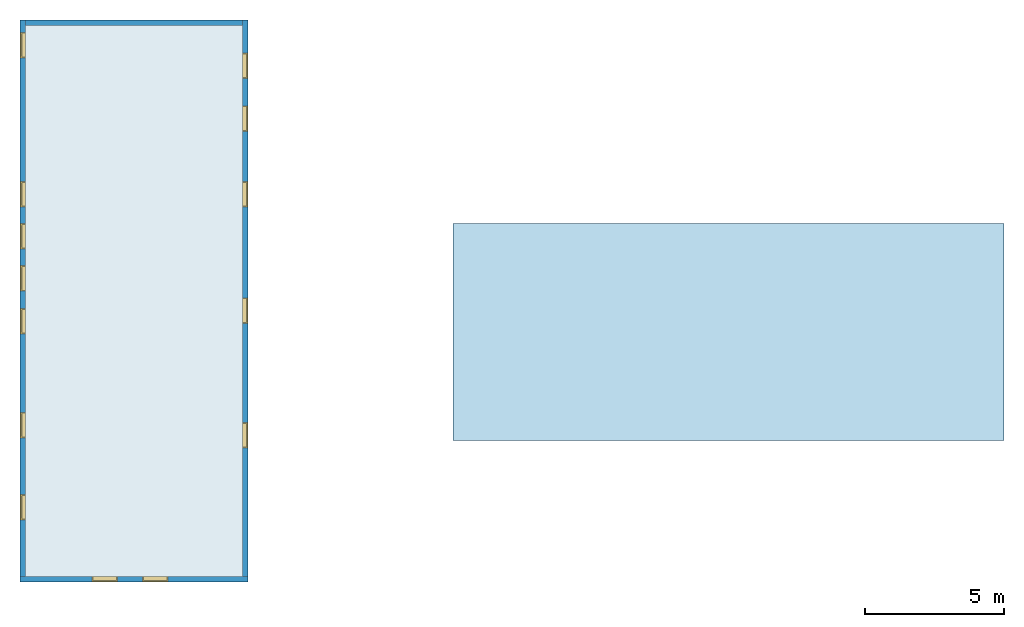
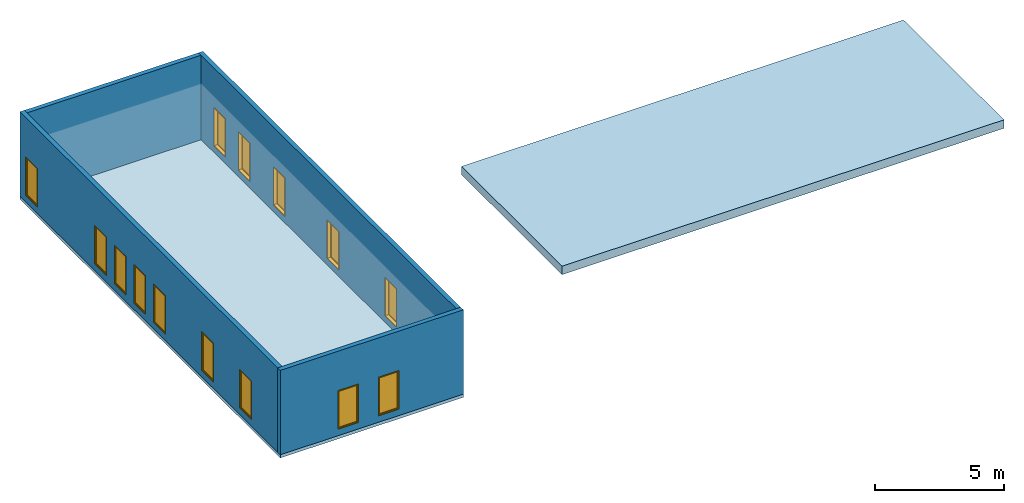
# One storey, part 1 of 2: 14 windows, 4 walls, 2 slabs, 14 openings, 1 element without a shape of its own.
"""IFC2X3 building model written with IfcOpenShell, lengths in millimetres."""

from ifc_helpers import new_model, entity, si_unit, converted_unit, derived_unit, direction, frame, frame_2d, origin, place, context, subcontext, project, spatial, polyline, rectangle, outline, extrude, source, transform, mapped, material, material_list, layer, layer_set, layer_usage, type_object, type_shapes, element, fill, aggregate, save


model = new_model("IFC2X3")

# Units and contexts
model_context = context("Model", 3, precision=0.01, world=origin(), true_north=direction((6.12303176911189e-17, 1.0)))
body_context = subcontext(model_context, "Body", "Model", "MODEL_VIEW")
ifc_project = project(units=[si_unit("LENGTHUNIT", "METRE", prefix="MILLI"), si_unit("AREAUNIT", "SQUARE_METRE"), si_unit("VOLUMEUNIT", "CUBIC_METRE"), converted_unit("PLANEANGLEUNIT", "DEGREE", entity("IfcRatioMeasure", 0.0174532925199433), si_unit("PLANEANGLEUNIT", "RADIAN"), dimensions=[0, 0, 0, 0, 0, 0, 0]), si_unit("MASSUNIT", "GRAM", prefix="KILO"), derived_unit("MASSDENSITYUNIT", [(si_unit("MASSUNIT", "GRAM", prefix="KILO"), 1), (si_unit("LENGTHUNIT", "METRE"), -3)]), derived_unit("MOMENTOFINERTIAUNIT", [(si_unit("LENGTHUNIT", "METRE"), 4)]), si_unit("TIMEUNIT", "SECOND"), si_unit("FREQUENCYUNIT", "HERTZ"), si_unit("THERMODYNAMICTEMPERATUREUNIT", "DEGREE_CELSIUS"), derived_unit("THERMALTRANSMITTANCEUNIT", [(si_unit("MASSUNIT", "GRAM", prefix="KILO"), 1), (si_unit("THERMODYNAMICTEMPERATUREUNIT", "KELVIN"), -1), (si_unit("TIMEUNIT", "SECOND"), -3)]), derived_unit("VOLUMETRICFLOWRATEUNIT", [(si_unit("LENGTHUNIT", "METRE"), 3), (si_unit("TIMEUNIT", "SECOND"), -1)]), si_unit("ELECTRICCURRENTUNIT", "AMPERE"), si_unit("ELECTRICVOLTAGEUNIT", "VOLT"), si_unit("POWERUNIT", "WATT"), si_unit("FORCEUNIT", "NEWTON", prefix="KILO"), si_unit("ILLUMINANCEUNIT", "LUX"), si_unit("LUMINOUSFLUXUNIT", "LUMEN"), si_unit("LUMINOUSINTENSITYUNIT", "CANDELA"), derived_unit("USERDEFINED", [(si_unit("MASSUNIT", "GRAM", prefix="KILO"), -1), (si_unit("LENGTHUNIT", "METRE"), -2), (si_unit("TIMEUNIT", "SECOND"), 3), (si_unit("LUMINOUSFLUXUNIT", "LUMEN"), 1)]), derived_unit("LINEARVELOCITYUNIT", [(si_unit("LENGTHUNIT", "METRE"), 1), (si_unit("TIMEUNIT", "SECOND"), -1)]), si_unit("PRESSUREUNIT", "PASCAL"), derived_unit("USERDEFINED", [(si_unit("LENGTHUNIT", "METRE"), -2), (si_unit("MASSUNIT", "GRAM", prefix="KILO"), 1), (si_unit("TIMEUNIT", "SECOND"), -2)]), derived_unit("LINEARFORCEUNIT", [(si_unit("MASSUNIT", "GRAM", prefix="KILO"), 1), (si_unit("LENGTHUNIT", "METRE"), 1), (si_unit("TIMEUNIT", "SECOND"), -2), (si_unit("LENGTHUNIT", "METRE"), -1)]), derived_unit("PLANARFORCEUNIT", [(si_unit("MASSUNIT", "GRAM", prefix="KILO"), 1), (si_unit("LENGTHUNIT", "METRE"), 1), (si_unit("TIMEUNIT", "SECOND"), -2), (si_unit("LENGTHUNIT", "METRE"), -2)])], contexts=[model_context])

# Site, building, storey
site_placement = place(None, origin())
site = spatial("IfcSite", under=ifc_project, at=site_placement, CompositionType="ELEMENT")
building_placement = place(site_placement, origin())
building = spatial("IfcBuilding", under=site, at=building_placement, Name="// BUILDING/NAME //", CompositionType="ELEMENT")
storey_placement = place(building_placement, frame((0.0, 0.0, 4000.0)))
storey = spatial("IfcBuildingStorey", under=building, at=storey_placement, Name="Level 2", CompositionType="ELEMENT", Elevation=4000.0)

# Slab
ifc_material_1 = material(Name="Default Floor")
ifc_layer_1 = layer(ifc_material_1, 150.0)
ifc_layer_set_1 = layer_set([ifc_layer_1], Name="Floor:Generic 150mm")
ifc_layer_usage_1 = layer_usage(ifc_layer_set_1, "AXIS3", "POSITIVE", 0.0)
slab_type_1 = type_object("IfcSlabType", Name="Floor:Generic 150mm", PredefinedType="FLOOR", material=ifc_layer_set_1)
slab_1_placement = place(storey_placement, origin())
element("IfcSlab", 1, at=slab_1_placement, inside=storey, type_object=slab_type_1, material=ifc_layer_usage_1, Name="Floor:Generic 150mm", ObjectType="Floor:Generic 150mm", PredefinedType="FLOOR", context=body_context, shape_type="SweptSolid", body=[
    extrude(rectangle(XDim=20200.0, YDim=8200.0, at=frame_2d((1.81898940354586e-12, 4.54747350886464e-13), x_axis=(1.0, 0.0))), frame((-10682.6678536818, -548.298444644712, 0.0), z_axis=(0.0, 0.0, -1.0), x_axis=(0.0, 1.0, 0.0)), (0.0, 0.0, 1.0), 150.0),
])

# Roof, slab
roof_placement = place(storey_placement, frame((783.073042068775, -5557.97302032133, 0.0)))
roof = element("IfcRoof", 2, at=roof_placement, inside=storey, Name="Basic Roof:Generic - 400mm", ObjectType="Basic Roof:Generic - 400mm", ShapeType="NOTDEFINED")
slab_type_2 = type_object("IfcSlabType", Name="Basic Roof:Generic - 400mm", PredefinedType="ROOF")
slab_2_placement = place(roof_placement, origin())
slab_2 = element("IfcSlab", 3, at=slab_2_placement, type_object=slab_type_2, Name="Basic Roof:Generic - 400mm", ObjectType="Basic Roof:Generic - 400mm", PredefinedType="NOTDEFINED", context=body_context, shape_type="SweptSolid", body=[
    extrude(rectangle(XDim=7800.0, YDim=19800.0, at=frame_2d((0.0, 0.0), x_axis=(0.0, 1.0))), frame((9900.0, 3900.0, 0.0)), (0.0, 0.0, 1.0), 400.0),
])
aggregate(roof, [slab_2])

# Wall, openings, windows
ifc_material_2 = material(Name="Default Wall")
ifc_layer_2 = layer(ifc_material_2, 200.0)
ifc_layer_set_2 = layer_set([ifc_layer_2], Name="Basic Wall:Outside wall")
ifc_layer_usage_2 = layer_usage(ifc_layer_set_2, "AXIS2", "NEGATIVE", 100.0)
wall_type = type_object("IfcWallType", Name="Basic Wall:Outside wall", PredefinedType="STANDARD", material=ifc_layer_set_2)
wall_1_placement = place(storey_placement, frame((-14782.6678536818, -10548.2984446447, 0.0)))
wall_1 = element("IfcWallStandardCase", 4, at=wall_1_placement, inside=storey, type_object=wall_type, material=ifc_layer_usage_2, Name="Basic Wall:Outside wall", ObjectType="Basic Wall:Outside wall", context=body_context, shape_type="SweptSolid", body=[
    extrude(rectangle(XDim=8200.0, YDim=199.999999999998, at=frame_2d((4100.0, 2.41584530158434e-13), x_axis=(-1.0, 0.0))), origin(), (0.0, 0.0, 1.0), 4000.0),
])
opening_1_placement = place(wall_1_placement, frame((3500.0, 100.0, 305.0)))
opening_1 = element("IfcOpeningElement", 5, at=opening_1_placement, cuts=wall_1, Name="M_Fixed:0915 x 1830mm:1", ObjectType="Opening", context=body_context, shape_type="SweptSolid", body=[
    extrude(rectangle(XDim=1830.0, YDim=914.999999999999, at=frame_2d((914.999999999999, 457.5), x_axis=(1.0, 0.0))), frame((0.0, 0.0, 0.0), z_axis=(0.0, -1.0, 0.0), x_axis=(0.0, 0.0, 1.0)), (0.0, 0.0, 1.0), 200.0),
])
opening_2_placement = place(wall_1_placement, frame((5315.0, 100.0, 305.0)))
opening_2 = element("IfcOpeningElement", 6, at=opening_2_placement, cuts=wall_1, Name="M_Fixed:0915 x 1830mm:1", ObjectType="Opening", context=body_context, shape_type="SweptSolid", body=[
    extrude(rectangle(XDim=1830.0, YDim=914.999999999999, at=frame_2d((914.999999999999, 457.5), x_axis=(1.0, 0.0))), frame((0.0, 0.0, 0.0), z_axis=(0.0, -1.0, 0.0), x_axis=(0.0, 0.0, 1.0)), (0.0, 0.0, 1.0), 200.0),
])
ifc_material_3 = material(Name="Glass")
ifc_material_4 = material(Name="Sash")
ifc_material_list_1 = material_list([ifc_material_3, ifc_material_4])
ifc_material_list_2 = material_list([ifc_material_3, ifc_material_4, ifc_material_4, ifc_material_4])
window_style = type_object("IfcWindowStyle", Name="M_Fixed:0915 x 1830mm", ConstructionType="NOTDEFINED", OperationType="NOTDEFINED", ParameterTakesPrecedence=False, Sizeable=False, material=ifc_material_list_2)
shared_shape = source(origin(), body_context, "Body", "SweptSolid", [
    extrude(rectangle(XDim=12.0, YDim=788.999999999997, at=frame_2d((8.43769498715119e-15, 0.0), x_axis=(1.0, 0.0))), frame((457.500000000006, 159.0, 63.0), z_axis=(0.0, 0.0, 1.0), x_axis=(0.0, -1.0, 0.0)), (0.0, 0.0, 1.0), 1704.00000000001),
    extrude(outline(polyline([(-438.5, -896.0), (438.5, -896.0), (438.5, 896.0), (-438.5, 896.0), (-438.5, -896.0)]), holes=[polyline([(-394.5, -852.0), (-394.5, 852.0), (394.499999999998, 852.0), (394.499999999998, -852.0), (-394.5, -852.0)])]), frame((457.500000000007, 137.0, 915.0), z_axis=(0.0, 1.0, 0.0), x_axis=(1.0, 0.0, 0.0)), (0.0, 0.0, 1.0), 44.0000000000274),
    extrude(outline(polyline([(-457.5, -915.0), (457.5, -915.0), (457.5, 915.0), (-457.5, 915.0), (-457.5, -915.0)]), holes=[polyline([(-438.500000000001, -896.0), (-438.500000000001, 896.0), (438.499999999999, 896.0), (438.499999999999, -896.0), (-438.500000000001, -896.0)])]), frame((457.500000000008, 137.0, 915.0), z_axis=(0.0, 1.0, 0.0), x_axis=(1.0, 0.0, 0.0)), (0.0, 0.0, 1.0), 63.0000000000274),
    extrude(outline(polyline([(-457.5, -915.0), (457.5, -915.0), (457.5, 915.0), (-457.5, 915.0), (-457.5, -915.0)]), holes=[polyline([(-425.5, -883.0), (-425.5, 883.0), (425.5, 883.0), (425.5, -883.0), (-425.5, -883.0)])]), frame((457.500000000008, 0.0, 915.0), z_axis=(0.0, 1.0, 0.0), x_axis=(1.0, 0.0, 0.0)), (0.0, 0.0, 1.0), 136.999999999973),
])
type_shapes(window_style, [shared_shape])
window_1_placement = place(opening_1_placement, frame((0.0, 0.0, 0.0), z_axis=(0.0, 0.0, 1.0), x_axis=(-1.0, 0.0, 0.0)))
window_1 = element("IfcWindow", 7, at=window_1_placement, inside=storey, type_object=window_style, material=ifc_material_list_1, Name="M_Fixed:0915 x 1830mm", ObjectType="M_Fixed:0915 x 1830mm", OverallHeight=1830.0, OverallWidth=915.0, context=body_context, shape_type="MappedRepresentation", body=[
    mapped(shared_shape, transform((0.0, 0.0, 0.0), scale=1.0)),
])
fill(opening_1, window_1)
ifc_material_list_3 = material_list([ifc_material_3, ifc_material_4])
window_2_placement = place(opening_2_placement, frame((0.0, 0.0, 0.0), z_axis=(0.0, 0.0, 1.0), x_axis=(-1.0, 0.0, 0.0)))
window_2 = element("IfcWindow", 8, at=window_2_placement, inside=storey, type_object=window_style, material=ifc_material_list_3, Name="M_Fixed:0915 x 1830mm", ObjectType="M_Fixed:0915 x 1830mm", OverallHeight=1830.0, OverallWidth=915.0, context=body_context, shape_type="MappedRepresentation", body=[
    mapped(shared_shape, transform((0.0, 0.0, 0.0), scale=1.0)),
])
fill(opening_2, window_2)

ifc_layer_usage_3 = layer_usage(ifc_layer_set_2, "AXIS2", "NEGATIVE", 100.0)
wall_2_placement = place(storey_placement, frame((-14682.6678536818, -10448.2984446447, 0.0), z_axis=(0.0, 0.0, 1.0), x_axis=(0.0, 1.0, 0.0)))
wall_2 = element("IfcWallStandardCase", 9, at=wall_2_placement, inside=storey, type_object=wall_type, material=ifc_layer_usage_3, Name="Basic Wall:Outside wall", ObjectType="Basic Wall:Outside wall", context=body_context, shape_type="SweptSolid", body=[
    extrude(rectangle(XDim=20000.0, YDim=199.999999999998, at=frame_2d((10000.0, 2.91322521661641e-13), x_axis=(-1.0, 0.0))), origin(), (0.0, 0.0, 1.0), 4000.0),
])
opening_3_placement = place(wall_2_placement, frame((13285.0, -100.0, 305.0)))
opening_3 = element("IfcOpeningElement", 10, at=opening_3_placement, cuts=wall_2, Name="M_Fixed:0915 x 1830mm:1", ObjectType="Opening", context=body_context, shape_type="SweptSolid", body=[
    extrude(rectangle(XDim=1830.0, YDim=914.999999999999, at=frame_2d((914.999999999999, 457.5), x_axis=(1.0, 0.0))), frame((0.0, 0.0, 0.0), z_axis=(0.0, 1.0, 0.0), x_axis=(0.0, 0.0, 1.0)), (0.0, 0.0, 1.0), 200.0),
])
opening_4_placement = place(wall_2_placement, frame((11770.0, -100.0, 305.0)))
opening_4 = element("IfcOpeningElement", 11, at=opening_4_placement, cuts=wall_2, Name="M_Fixed:0915 x 1830mm:1", ObjectType="Opening", context=body_context, shape_type="SweptSolid", body=[
    extrude(rectangle(XDim=1830.0, YDim=914.999999999999, at=frame_2d((914.999999999999, 457.5), x_axis=(1.0, 0.0))), frame((0.0, 0.0, 0.0), z_axis=(0.0, 1.0, 0.0), x_axis=(0.0, 0.0, 1.0)), (0.0, 0.0, 1.0), 200.0),
])
opening_5_placement = place(wall_2_placement, frame((10255.0, -100.0, 305.0)))
opening_5 = element("IfcOpeningElement", 12, at=opening_5_placement, cuts=wall_2, Name="M_Fixed:0915 x 1830mm:1", ObjectType="Opening", context=body_context, shape_type="SweptSolid", body=[
    extrude(rectangle(XDim=1830.0, YDim=914.999999999999, at=frame_2d((914.999999999999, 457.5), x_axis=(1.0, 0.0))), frame((0.0, 0.0, 0.0), z_axis=(0.0, 1.0, 0.0), x_axis=(0.0, 0.0, 1.0)), (0.0, 0.0, 1.0), 200.0),
])
opening_6_placement = place(wall_2_placement, frame((8720.0, -100.0, 305.0)))
opening_6 = element("IfcOpeningElement", 13, at=opening_6_placement, cuts=wall_2, Name="M_Fixed:0915 x 1830mm:1", ObjectType="Opening", context=body_context, shape_type="SweptSolid", body=[
    extrude(rectangle(XDim=1830.0, YDim=914.999999999999, at=frame_2d((914.999999999999, 457.5), x_axis=(1.0, 0.0))), frame((0.0, 0.0, 0.0), z_axis=(0.0, 1.0, 0.0), x_axis=(0.0, 0.0, 1.0)), (0.0, 0.0, 1.0), 200.0),
])
opening_7_placement = place(wall_2_placement, frame((4985.0, -100.0, 305.0)))
opening_7 = element("IfcOpeningElement", 14, at=opening_7_placement, cuts=wall_2, Name="M_Fixed:0915 x 1830mm:1", ObjectType="Opening", context=body_context, shape_type="SweptSolid", body=[
    extrude(rectangle(XDim=1830.0, YDim=914.999999999999, at=frame_2d((914.999999999999, 457.5), x_axis=(1.0, 0.0))), frame((0.0, 0.0, 0.0), z_axis=(0.0, 1.0, 0.0), x_axis=(0.0, 0.0, 1.0)), (0.0, 0.0, 1.0), 200.0),
])
opening_8_placement = place(wall_2_placement, frame((2035.0, -100.0, 305.0)))
opening_8 = element("IfcOpeningElement", 15, at=opening_8_placement, cuts=wall_2, Name="M_Fixed:0915 x 1830mm:1", ObjectType="Opening", context=body_context, shape_type="SweptSolid", body=[
    extrude(rectangle(XDim=1830.0, YDim=914.999999999999, at=frame_2d((914.999999999999, 457.5), x_axis=(1.0, 0.0))), frame((0.0, 0.0, 0.0), z_axis=(0.0, 1.0, 0.0), x_axis=(0.0, 0.0, 1.0)), (0.0, 0.0, 1.0), 200.0),
])
opening_9_placement = place(wall_2_placement, frame((18642.5, -100.0, 305.0)))
opening_9 = element("IfcOpeningElement", 16, at=opening_9_placement, cuts=wall_2, Name="M_Fixed:0915 x 1830mm:1", ObjectType="Opening", context=body_context, shape_type="SweptSolid", body=[
    extrude(rectangle(XDim=1830.0, YDim=914.999999999999, at=frame_2d((914.999999999999, 457.5), x_axis=(1.0, 0.0))), frame((0.0, 0.0, 0.0), z_axis=(0.0, 1.0, 0.0), x_axis=(0.0, 0.0, 1.0)), (0.0, 0.0, 1.0), 200.0),
])
ifc_material_list_4 = material_list([ifc_material_3, ifc_material_4])
window_3_placement = place(opening_3_placement, origin())
window_3 = element("IfcWindow", 17, at=window_3_placement, inside=storey, type_object=window_style, material=ifc_material_list_4, Name="M_Fixed:0915 x 1830mm", ObjectType="M_Fixed:0915 x 1830mm", OverallHeight=1830.0, OverallWidth=914.999999999999, context=body_context, shape_type="MappedRepresentation", body=[
    mapped(shared_shape, transform((0.0, 0.0, 0.0), scale=1.0)),
])
fill(opening_3, window_3)
ifc_material_list_5 = material_list([ifc_material_3, ifc_material_4])
window_4_placement = place(opening_4_placement, origin())
window_4 = element("IfcWindow", 18, at=window_4_placement, inside=storey, type_object=window_style, material=ifc_material_list_5, Name="M_Fixed:0915 x 1830mm", ObjectType="M_Fixed:0915 x 1830mm", OverallHeight=1830.0, OverallWidth=914.999999999999, context=body_context, shape_type="MappedRepresentation", body=[
    mapped(shared_shape, transform((0.0, 0.0, 0.0), scale=1.0)),
])
fill(opening_4, window_4)
ifc_material_list_6 = material_list([ifc_material_3, ifc_material_4])
window_5_placement = place(opening_5_placement, origin())
window_5 = element("IfcWindow", 19, at=window_5_placement, inside=storey, type_object=window_style, material=ifc_material_list_6, Name="M_Fixed:0915 x 1830mm", ObjectType="M_Fixed:0915 x 1830mm", OverallHeight=1830.0, OverallWidth=914.999999999999, context=body_context, shape_type="MappedRepresentation", body=[
    mapped(shared_shape, transform((0.0, 0.0, 0.0), scale=1.0)),
])
fill(opening_5, window_5)
ifc_material_list_7 = material_list([ifc_material_3, ifc_material_4])
window_6_placement = place(opening_6_placement, origin())
window_6 = element("IfcWindow", 20, at=window_6_placement, inside=storey, type_object=window_style, material=ifc_material_list_7, Name="M_Fixed:0915 x 1830mm", ObjectType="M_Fixed:0915 x 1830mm", OverallHeight=1830.0, OverallWidth=915.0, context=body_context, shape_type="MappedRepresentation", body=[
    mapped(shared_shape, transform((0.0, 0.0, 0.0), scale=1.0)),
])
fill(opening_6, window_6)
ifc_material_list_8 = material_list([ifc_material_3, ifc_material_4])
window_7_placement = place(opening_7_placement, origin())
window_7 = element("IfcWindow", 21, at=window_7_placement, inside=storey, type_object=window_style, material=ifc_material_list_8, Name="M_Fixed:0915 x 1830mm", ObjectType="M_Fixed:0915 x 1830mm", OverallHeight=1830.0, OverallWidth=914.999999999999, context=body_context, shape_type="MappedRepresentation", body=[
    mapped(shared_shape, transform((0.0, 0.0, 0.0), scale=1.0)),
])
fill(opening_7, window_7)
ifc_material_list_9 = material_list([ifc_material_3, ifc_material_4])
window_8_placement = place(opening_8_placement, origin())
window_8 = element("IfcWindow", 22, at=window_8_placement, inside=storey, type_object=window_style, material=ifc_material_list_9, Name="M_Fixed:0915 x 1830mm", ObjectType="M_Fixed:0915 x 1830mm", OverallHeight=1830.0, OverallWidth=915.0, context=body_context, shape_type="MappedRepresentation", body=[
    mapped(shared_shape, transform((0.0, 0.0, 0.0), scale=1.0)),
])
fill(opening_8, window_8)
ifc_material_list_10 = material_list([ifc_material_3, ifc_material_4])
window_9_placement = place(opening_9_placement, origin())
window_9 = element("IfcWindow", 23, at=window_9_placement, inside=storey, type_object=window_style, material=ifc_material_list_10, Name="M_Fixed:0915 x 1830mm", ObjectType="M_Fixed:0915 x 1830mm", OverallHeight=1830.0, OverallWidth=915.0, context=body_context, shape_type="MappedRepresentation", body=[
    mapped(shared_shape, transform((0.0, 0.0, 0.0), scale=1.0)),
])
fill(opening_9, window_9)

ifc_layer_usage_4 = layer_usage(ifc_layer_set_2, "AXIS2", "NEGATIVE", 100.0)
wall_3_placement = place(storey_placement, frame((-6682.66785368182, -10448.2984446447, 0.0), z_axis=(0.0, 0.0, 1.0), x_axis=(0.0, 1.0, 0.0)))
wall_3 = element("IfcWallStandardCase", 24, at=wall_3_placement, inside=storey, type_object=wall_type, material=ifc_layer_usage_4, Name="Basic Wall:Outside wall", ObjectType="Basic Wall:Outside wall", context=body_context, shape_type="SweptSolid", body=[
    extrude(rectangle(XDim=20000.0, YDim=200.0, at=frame_2d((10000.0, 0.0), x_axis=(-1.0, 0.0))), origin(), (0.0, 0.0, 1.0), 4000.0),
])
opening_10_placement = place(wall_3_placement, frame((5537.5, 100.0, 305.0)))
opening_10 = element("IfcOpeningElement", 25, at=opening_10_placement, cuts=wall_3, Name="M_Fixed:0915 x 1830mm:1", ObjectType="Opening", context=body_context, shape_type="SweptSolid", body=[
    extrude(rectangle(XDim=1830.0, YDim=914.999999999999, at=frame_2d((914.999999999999, 457.5), x_axis=(1.0, 0.0))), frame((0.0, 0.0, 0.0), z_axis=(0.0, -1.0, 0.0), x_axis=(0.0, 0.0, 1.0)), (0.0, 0.0, 1.0), 200.0),
])
opening_11_placement = place(wall_3_placement, frame((10015.0, 100.0, 305.0)))
opening_11 = element("IfcOpeningElement", 26, at=opening_11_placement, cuts=wall_3, Name="M_Fixed:0915 x 1830mm:1", ObjectType="Opening", context=body_context, shape_type="SweptSolid", body=[
    extrude(rectangle(XDim=1830.0, YDim=914.999999999999, at=frame_2d((914.999999999999, 457.5), x_axis=(1.0, 0.0))), frame((0.0, 0.0, 0.0), z_axis=(0.0, -1.0, 0.0), x_axis=(0.0, 0.0, 1.0)), (0.0, 0.0, 1.0), 200.0),
])
opening_12_placement = place(wall_3_placement, frame((14200.0, 100.0, 305.0)))
opening_12 = element("IfcOpeningElement", 27, at=opening_12_placement, cuts=wall_3, Name="M_Fixed:0915 x 1830mm:1", ObjectType="Opening", context=body_context, shape_type="SweptSolid", body=[
    extrude(rectangle(XDim=1830.0, YDim=914.999999999999, at=frame_2d((914.999999999999, 457.5), x_axis=(1.0, 0.0))), frame((0.0, 0.0, 0.0), z_axis=(0.0, -1.0, 0.0), x_axis=(0.0, 0.0, 1.0)), (0.0, 0.0, 1.0), 200.0),
])
opening_13_placement = place(wall_3_placement, frame((16915.0, 100.0, 305.0)))
opening_13 = element("IfcOpeningElement", 28, at=opening_13_placement, cuts=wall_3, Name="M_Fixed:0915 x 1830mm:1", ObjectType="Opening", context=body_context, shape_type="SweptSolid", body=[
    extrude(rectangle(XDim=1830.0, YDim=914.999999999999, at=frame_2d((914.999999999999, 457.5), x_axis=(1.0, 0.0))), frame((0.0, 0.0, 0.0), z_axis=(0.0, -1.0, 0.0), x_axis=(0.0, 0.0, 1.0)), (0.0, 0.0, 1.0), 200.0),
])
opening_14_placement = place(wall_3_placement, frame((18815.0, 100.0, 305.0)))
opening_14 = element("IfcOpeningElement", 29, at=opening_14_placement, cuts=wall_3, Name="M_Fixed:0915 x 1830mm:1", ObjectType="Opening", context=body_context, shape_type="SweptSolid", body=[
    extrude(rectangle(XDim=1830.0, YDim=914.999999999999, at=frame_2d((914.999999999999, 457.5), x_axis=(1.0, 0.0))), frame((0.0, 0.0, 0.0), z_axis=(0.0, -1.0, 0.0), x_axis=(0.0, 0.0, 1.0)), (0.0, 0.0, 1.0), 200.0),
])
ifc_material_list_11 = material_list([ifc_material_3, ifc_material_4])
window_10_placement = place(opening_10_placement, frame((0.0, 0.0, 0.0), z_axis=(0.0, 0.0, 1.0), x_axis=(-1.0, 0.0, 0.0)))
window_10 = element("IfcWindow", 30, at=window_10_placement, inside=storey, type_object=window_style, material=ifc_material_list_11, Name="M_Fixed:0915 x 1830mm", ObjectType="M_Fixed:0915 x 1830mm", OverallHeight=1830.0, OverallWidth=915.0, context=body_context, shape_type="MappedRepresentation", body=[
    mapped(shared_shape, transform((0.0, 0.0, 0.0), scale=1.0)),
])
fill(opening_10, window_10)
ifc_material_list_12 = material_list([ifc_material_3, ifc_material_4])
window_11_placement = place(opening_11_placement, frame((0.0, 0.0, 0.0), z_axis=(0.0, 0.0, 1.0), x_axis=(-1.0, 0.0, 0.0)))
window_11 = element("IfcWindow", 31, at=window_11_placement, inside=storey, type_object=window_style, material=ifc_material_list_12, Name="M_Fixed:0915 x 1830mm", ObjectType="M_Fixed:0915 x 1830mm", OverallHeight=1830.0, OverallWidth=914.999999999999, context=body_context, shape_type="MappedRepresentation", body=[
    mapped(shared_shape, transform((0.0, 0.0, 0.0), scale=1.0)),
])
fill(opening_11, window_11)
ifc_material_list_13 = material_list([ifc_material_3, ifc_material_4])
window_12_placement = place(opening_12_placement, frame((0.0, 0.0, 0.0), z_axis=(0.0, 0.0, 1.0), x_axis=(-1.0, 0.0, 0.0)))
window_12 = element("IfcWindow", 32, at=window_12_placement, inside=storey, type_object=window_style, material=ifc_material_list_13, Name="M_Fixed:0915 x 1830mm", ObjectType="M_Fixed:0915 x 1830mm", OverallHeight=1830.0, OverallWidth=914.999999999999, context=body_context, shape_type="MappedRepresentation", body=[
    mapped(shared_shape, transform((0.0, 0.0, 0.0), scale=1.0)),
])
fill(opening_12, window_12)
ifc_material_list_14 = material_list([ifc_material_3, ifc_material_4])
window_13_placement = place(opening_13_placement, frame((0.0, 0.0, 0.0), z_axis=(0.0, 0.0, 1.0), x_axis=(-1.0, 0.0, 0.0)))
window_13 = element("IfcWindow", 33, at=window_13_placement, inside=storey, type_object=window_style, material=ifc_material_list_14, Name="M_Fixed:0915 x 1830mm", ObjectType="M_Fixed:0915 x 1830mm", OverallHeight=1830.0, OverallWidth=915.0, context=body_context, shape_type="MappedRepresentation", body=[
    mapped(shared_shape, transform((0.0, 0.0, 0.0), scale=1.0)),
])
fill(opening_13, window_13)
ifc_material_list_15 = material_list([ifc_material_3, ifc_material_4])
window_14_placement = place(opening_14_placement, frame((0.0, 0.0, 0.0), z_axis=(0.0, 0.0, 1.0), x_axis=(-1.0, 0.0, 0.0)))
window_14 = element("IfcWindow", 34, at=window_14_placement, inside=storey, type_object=window_style, material=ifc_material_list_15, Name="M_Fixed:0915 x 1830mm", ObjectType="M_Fixed:0915 x 1830mm", OverallHeight=1830.0, OverallWidth=915.0, context=body_context, shape_type="MappedRepresentation", body=[
    mapped(shared_shape, transform((0.0, 0.0, 0.0), scale=1.0)),
])
fill(opening_14, window_14)

# Wall
ifc_layer_usage_5 = layer_usage(ifc_layer_set_2, "AXIS2", "NEGATIVE", 100.0)
wall_4_placement = place(storey_placement, frame((-6782.66785368179, 9451.70155535529, 0.0), z_axis=(0.0, 0.0, 1.0), x_axis=(-1.0, 0.0, 0.0)))
element("IfcWallStandardCase", 35, at=wall_4_placement, inside=storey, type_object=wall_type, material=ifc_layer_usage_5, Name="Basic Wall:Outside wall", ObjectType="Basic Wall:Outside wall", context=body_context, shape_type="SweptSolid", body=[
    extrude(rectangle(XDim=7800.0, YDim=200.0, at=frame_2d((3900.0, -3.19744231092045e-13), x_axis=(-1.0, 0.0))), origin(), (0.0, 0.0, 1.0), 4000.0),
])

save(model, "model.ifc")
